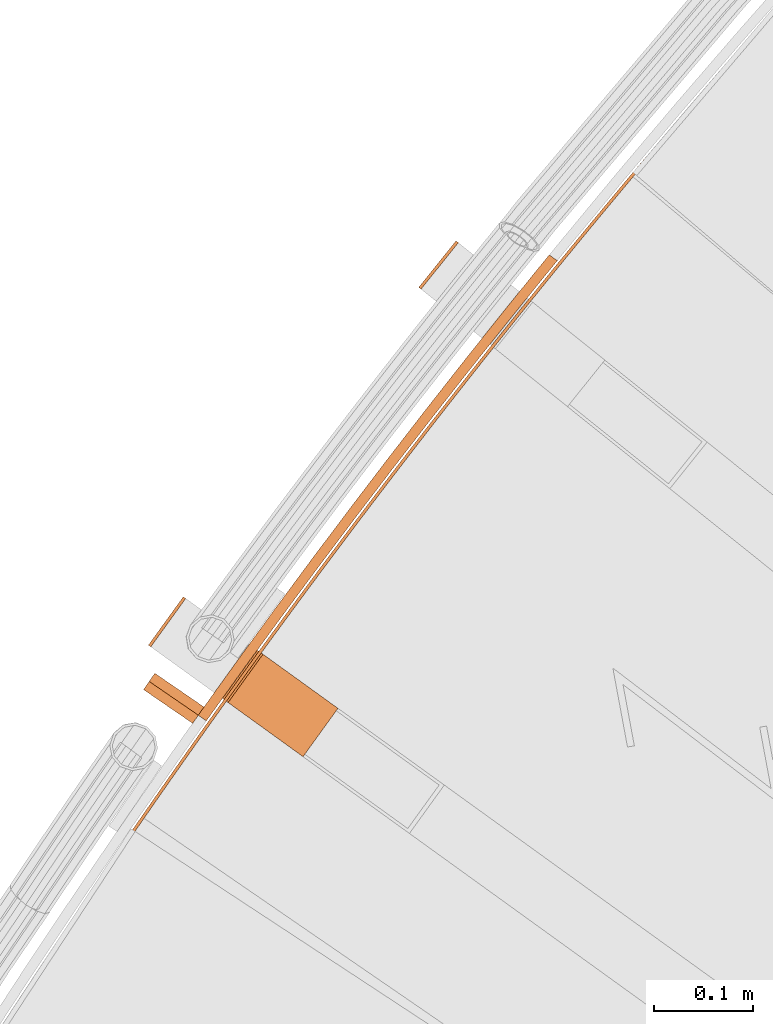
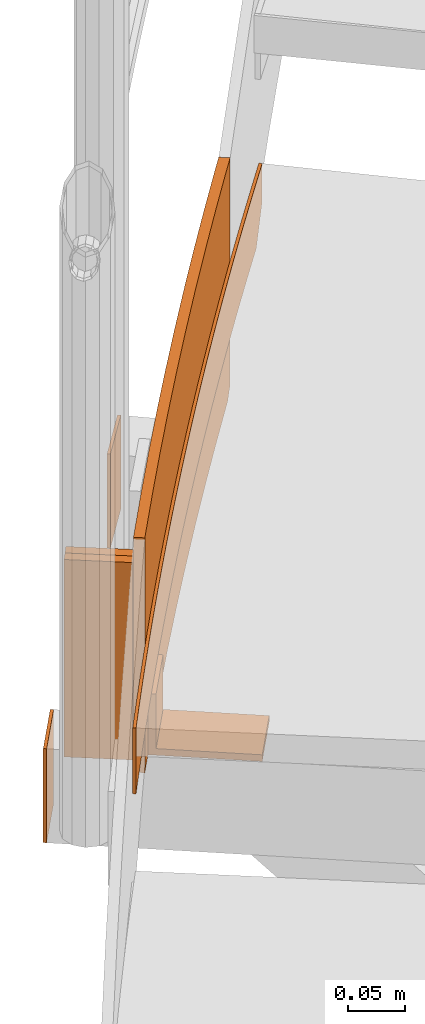
# One storey, part 64 of 126: 7 proxies.
"""IFC2X3 building model written with IfcOpenShell, lengths in millimetres."""

from ifc_helpers import new_model, si_unit, origin, origin_with_axes, place, context, project, spatial, faceted_brep, material, element, save


model = new_model("IFC2X3")

# Units and contexts
context_of_model_1 = context(None, 3, precision=0.1, world=origin())
context_of_model_2 = context(None, 3, precision=0.1, world=origin())
ifc_project = project(units=[si_unit("LENGTHUNIT", "METRE", prefix="MILLI"), si_unit("AREAUNIT", "SQUARE_METRE", prefix="CENTI"), si_unit("VOLUMEUNIT", "CUBIC_METRE", prefix="CENTI"), si_unit("MASSUNIT", "GRAM", prefix="KILO")], contexts=[context_of_model_1, context_of_model_2])

# Site, building, storey
site_placement = place(None, origin_with_axes())
site = spatial("IfcSite", under=ifc_project, at=site_placement, CompositionType="ELEMENT")
building_placement = place(site_placement, origin_with_axes())
building = spatial("IfcBuilding", under=site, at=building_placement, CompositionType="ELEMENT")
storey_placement = place(building_placement, origin_with_axes())
storey = spatial("IfcBuildingStorey", under=building, at=storey_placement, CompositionType="ELEMENT")

# Proxies
ifc_material = material(Name="S235JRG2")
proxy_1_placement = place(storey_placement, origin_with_axes())
element("IfcBuildingElementProxy", 1, at=proxy_1_placement, inside=storey, material=ifc_material, context=context_of_model_2, shape_type="Brep", body=[
    faceted_brep([(816.2356, 13130.803, 8163.85), (824.3778, 13124.997, 8163.85), (819.9333, 13118.718, 8163.85), (811.6902, 13124.381, 8163.85), (824.3778, 13124.997, 8413.85), (819.9333, 13118.718, 8413.85), (816.2356, 13130.803, 8413.85), (811.6902, 13124.381, 8413.85), (852.1953, 13180.865, 8163.85), (860.2968, 13175.002, 8163.85), (860.2968, 13175.002, 8413.85), (852.1953, 13180.865, 8413.85), (888.5037, 13230.674, 8163.85), (896.564, 13224.755, 8163.85), (896.564, 13224.755, 8413.85), (888.5037, 13230.674, 8413.85), (925.1589, 13280.229, 8163.85), (933.1777, 13274.254, 8163.85), (933.1777, 13274.254, 8413.85), (925.1589, 13280.229, 8413.85), (962.1592, 13329.527, 8163.85), (970.1361, 13323.496, 8163.85), (970.1361, 13323.496, 8413.85), (962.1592, 13329.527, 8413.85), (999.5027, 13378.565, 8163.85), (1007.4374, 13372.478, 8163.85), (1007.4374, 13372.478, 8413.85), (999.5027, 13378.565, 8413.85), (1037.1877, 13427.341, 8163.85), (1045.0796, 13421.2, 8163.85), (1045.0796, 13421.2, 8413.85), (1037.1877, 13427.341, 8413.85), (1075.2123, 13475.853, 8163.85), (1083.0612, 13469.657, 8163.85), (1083.0612, 13469.657, 8413.85), (1075.2123, 13475.853, 8413.85), (1113.5746, 13524.098, 8163.85), (1121.38, 13517.847, 8163.85), (1121.38, 13517.847, 8413.85), (1113.5746, 13524.098, 8413.85), (1152.2728, 13572.075, 8163.85), (1160.0344, 13565.769, 8163.85), (1160.0344, 13565.769, 8413.85), (1152.2728, 13572.075, 8413.85), (1156.1112, 13576.766, 8163.85), (1164.3824, 13571.083, 8163.85), (1173.0338, 13581.657, 8172.9603), (1173.0338, 13581.657, 8413.85), (1164.7625, 13587.34, 8413.85), (1164.7625, 13587.34, 8172.9603)], [[[0, 1, 2, 3]], [[1, 4, 5, 2]], [[4, 6, 7, 5]], [[0, 3, 7, 6]], [[0, 8, 9, 1]], [[1, 9, 10, 4]], [[4, 10, 11, 6]], [[6, 11, 8, 0]], [[8, 12, 13, 9]], [[9, 13, 14, 10]], [[10, 14, 15, 11]], [[11, 15, 12, 8]], [[12, 16, 17, 13]], [[13, 17, 18, 14]], [[14, 18, 19, 15]], [[15, 19, 16, 12]], [[16, 20, 21, 17]], [[17, 21, 22, 18]], [[18, 22, 23, 19]], [[19, 23, 20, 16]], [[20, 24, 25, 21]], [[21, 25, 26, 22]], [[22, 26, 27, 23]], [[23, 27, 24, 20]], [[24, 28, 29, 25]], [[25, 29, 30, 26]], [[26, 30, 31, 27]], [[27, 31, 28, 24]], [[28, 32, 33, 29]], [[29, 33, 34, 30]], [[30, 34, 35, 31]], [[31, 35, 32, 28]], [[32, 36, 37, 33]], [[33, 37, 38, 34]], [[34, 38, 39, 35]], [[35, 39, 36, 32]], [[36, 40, 41, 37]], [[37, 41, 42, 38]], [[38, 42, 43, 39]], [[39, 43, 40, 36]], [[40, 44, 45, 41]], [[41, 45, 46, 47, 42]], [[42, 47, 48, 43]], [[40, 43, 48, 49, 44]], [[46, 49, 48, 47]], [[44, 49, 46, 45]], [[2, 5, 7, 3]]]),
])
proxy_2_placement = place(storey_placement, origin_with_axes())
element("IfcBuildingElementProxy", 2, at=proxy_2_placement, inside=storey, material=ifc_material, context=context_of_model_2, shape_type="Brep", body=[
    faceted_brep([(796.7953, 13243.586, 8063.8501), (799.2281, 13241.83, 8063.8501), (764.1179, 13193.176, 8063.8501), (761.6852, 13194.931, 8063.8501), (796.7953, 13243.586, 8163.85), (761.6852, 13194.931, 8163.85), (764.1179, 13193.176, 8163.85), (799.2281, 13241.83, 8163.85)], [[[0, 1, 2, 3]], [[4, 5, 6, 7]], [[0, 4, 7, 1]], [[1, 7, 6, 2]], [[2, 6, 5, 3]], [[3, 5, 4, 0]]]),
])
proxy_3_placement = place(storey_placement, origin_with_axes())
element("IfcBuildingElementProxy", 3, at=proxy_3_placement, inside=storey, material=ifc_material, context=context_of_model_2, shape_type="Brep", body=[
    faceted_brep([(1071.0619, 13601.561, 8063.8501), (1073.4027, 13599.685, 8063.8501), (1035.8759, 13552.869, 8063.8501), (1033.5351, 13554.745, 8063.8501), (1071.0619, 13601.561, 8163.85), (1033.5351, 13554.745, 8163.85), (1035.8759, 13552.869, 8163.85), (1073.4027, 13599.685, 8163.85)], [[[0, 1, 2, 3]], [[4, 5, 6, 7]], [[0, 4, 7, 1]], [[1, 7, 6, 2]], [[2, 6, 5, 3]], [[3, 5, 4, 0]]]),
])
proxy_4_placement = place(storey_placement, origin_with_axes())
element("IfcBuildingElementProxy", 4, at=proxy_4_placement, inside=storey, material=ifc_material, context=context_of_model_2, shape_type="Brep", body=[
    faceted_brep([(737.806, 12997.733, 8243.85), (740.2786, 12996.034, 8243.85), (740.2786, 12996.034, 8313.85), (737.806, 12997.733, 8313.85), (742.7055, 13004.864, 8243.85), (745.1765, 13003.163, 8243.85), (745.1765, 13003.163, 8313.85), (742.7055, 13004.864, 8313.85), (752.5327, 13019.108, 8243.85), (755.0004, 13017.402, 8243.85), (755.0004, 13017.402, 8313.85), (752.5327, 13019.108, 8313.85), (762.3878, 13033.333, 8243.85), (764.8521, 13031.622, 8243.85), (764.8521, 13031.622, 8313.85), (762.3878, 13033.333, 8313.85), (772.2708, 13047.538, 8243.85), (774.7317, 13045.822, 8243.85), (774.7317, 13045.822, 8313.85), (772.2708, 13047.538, 8313.85), (782.1816, 13061.724, 8243.85), (784.6392, 13060.003, 8243.85), (784.6392, 13060.003, 8313.85), (782.1816, 13061.724, 8313.85), (792.1203, 13075.89, 8243.85), (794.5745, 13074.165, 8243.85), (794.5745, 13074.165, 8313.85), (792.1203, 13075.89, 8313.85), (802.0867, 13090.037, 8243.85), (804.5375, 13088.307, 8243.85), (804.5375, 13088.307, 8313.85), (802.0867, 13090.037, 8313.85), (812.0809, 13104.164, 8243.85), (814.5284, 13102.429, 8243.85), (814.5284, 13102.429, 8313.85), (812.0809, 13104.164, 8313.85), (822.1029, 13118.272, 8243.85), (824.5469, 13116.532, 8243.85), (824.5469, 13116.532, 8313.85), (822.1029, 13118.272, 8313.85), (832.1524, 13132.36, 8243.85), (834.593, 13130.615, 8243.85), (834.593, 13130.615, 8313.85), (832.1524, 13132.36, 8313.85), (842.2297, 13146.428, 8243.85), (844.6668, 13144.679, 8243.85), (844.6668, 13144.679, 8313.85), (842.2297, 13146.428, 8313.85), (852.3345, 13160.476, 8243.85), (854.7682, 13158.722, 8243.85), (854.7682, 13158.722, 8313.85), (852.3345, 13160.476, 8313.85), (862.4668, 13174.505, 8243.85), (864.8971, 13172.746, 8243.85), (864.8971, 13172.746, 8313.85), (862.4668, 13174.505, 8313.85), (872.6267, 13188.513, 8243.85), (875.0535, 13186.75, 8243.85), (875.0535, 13186.75, 8313.85), (872.6267, 13188.513, 8313.85), (882.814, 13202.502, 8243.85), (885.2374, 13200.733, 8243.85), (885.2374, 13200.733, 8313.85), (882.814, 13202.502, 8313.85), (893.0288, 13216.47, 8243.85), (895.4487, 13214.697, 8243.85), (895.4487, 13214.697, 8313.85), (893.0288, 13216.47, 8313.85), (903.271, 13230.419, 8243.85), (905.6874, 13228.641, 8243.85), (905.6874, 13228.641, 8313.85), (903.271, 13230.419, 8313.85), (913.5405, 13244.347, 8243.85), (915.9534, 13242.565, 8243.85), (915.9534, 13242.565, 8313.85), (913.5405, 13244.347, 8313.85), (923.8374, 13258.255, 8243.85), (926.2467, 13256.468, 8243.85), (926.2467, 13256.468, 8313.85), (923.8374, 13258.255, 8313.85), (934.1615, 13272.143, 8243.85), (936.5674, 13270.351, 8243.85), (936.5674, 13270.351, 8313.85), (934.1615, 13272.143, 8313.85), (944.5129, 13286.011, 8243.85), (946.9152, 13284.214, 8243.85), (946.9152, 13284.214, 8313.85), (944.5129, 13286.011, 8313.85), (954.8914, 13299.858, 8243.85), (957.2902, 13298.057, 8243.85), (957.2902, 13298.057, 8313.85), (954.8914, 13299.858, 8313.85), (965.2972, 13313.685, 8243.85), (967.6924, 13311.879, 8243.85), (967.6924, 13311.879, 8313.85), (965.2972, 13313.685, 8313.85), (975.73, 13327.492, 8243.85), (978.1217, 13325.681, 8243.85), (978.1217, 13325.681, 8313.85), (975.73, 13327.492, 8313.85), (986.1899, 13341.278, 8243.85), (988.5781, 13339.462, 8243.85), (988.5781, 13339.462, 8313.85), (986.1899, 13341.278, 8313.85), (996.6769, 13355.043, 8243.85), (999.0615, 13353.223, 8243.85), (999.0615, 13353.223, 8313.85), (996.6769, 13355.043, 8313.85), (1007.1908, 13368.788, 8243.85), (1009.5718, 13366.963, 8243.85), (1009.5718, 13366.963, 8313.85), (1007.1908, 13368.788, 8313.85), (1017.7317, 13382.512, 8243.85), (1020.1092, 13380.682, 8243.85), (1020.1092, 13380.682, 8313.85), (1017.7317, 13382.512, 8313.85), (1028.2995, 13396.216, 8243.85), (1030.6734, 13394.381, 8243.85), (1030.6734, 13394.381, 8313.85), (1028.2995, 13396.216, 8313.85), (1038.8942, 13409.898, 8243.85), (1041.2645, 13408.059, 8243.85), (1041.2645, 13408.059, 8313.85), (1038.8942, 13409.898, 8313.85), (1049.5158, 13423.56, 8243.85), (1051.8824, 13421.716, 8243.85), (1051.8824, 13421.716, 8313.85), (1049.5158, 13423.56, 8313.85), (1060.1641, 13437.201, 8243.85), (1062.5271, 13435.353, 8243.85), (1062.5271, 13435.353, 8313.85), (1060.1641, 13437.201, 8313.85), (1070.8392, 13450.821, 8243.85), (1073.1985, 13448.968, 8243.85), (1073.1985, 13448.968, 8313.85), (1070.8392, 13450.821, 8313.85), (1081.541, 13464.42, 8243.85), (1083.8967, 13462.562, 8243.85), (1083.8967, 13462.562, 8313.85), (1081.541, 13464.42, 8313.85), (1092.2694, 13477.998, 8243.85), (1094.6215, 13476.136, 8243.85), (1094.6215, 13476.136, 8313.85), (1092.2694, 13477.998, 8313.85), (1103.0245, 13491.555, 8243.85), (1105.3729, 13489.688, 8243.85), (1105.3729, 13489.688, 8313.85), (1103.0245, 13491.555, 8313.85), (1113.8062, 13505.091, 8243.85), (1116.1509, 13503.219, 8243.85), (1116.1509, 13503.219, 8313.85), (1113.8062, 13505.091, 8313.85), (1124.6144, 13518.605, 8243.85), (1126.9555, 13516.729, 8243.85), (1126.9555, 13516.729, 8313.85), (1124.6144, 13518.605, 8313.85), (1135.4492, 13532.099, 8243.85), (1137.7865, 13530.218, 8243.85), (1137.7865, 13530.218, 8313.85), (1135.4492, 13532.099, 8313.85), (1146.3103, 13545.571, 8243.85), (1148.644, 13543.686, 8243.85), (1148.644, 13543.686, 8313.85), (1146.3103, 13545.571, 8313.85), (1157.1979, 13559.022, 8243.85), (1159.5279, 13557.132, 8243.85), (1159.5279, 13557.132, 8313.85), (1157.1979, 13559.022, 8313.85), (1168.1119, 13572.451, 8243.85), (1170.4382, 13570.557, 8243.85), (1170.4382, 13570.557, 8313.85), (1168.1119, 13572.451, 8313.85), (1179.0523, 13585.859, 8243.85), (1181.3748, 13583.96, 8243.85), (1181.3748, 13583.96, 8313.85), (1179.0523, 13585.859, 8313.85), (1190.0189, 13599.245, 8243.85), (1192.3377, 13597.342, 8243.85), (1192.3377, 13597.342, 8313.85), (1190.0189, 13599.245, 8313.85), (1201.0117, 13612.61, 8243.85), (1203.3268, 13610.702, 8243.85), (1203.3268, 13610.702, 8313.85), (1201.0117, 13612.61, 8313.85), (1212.0308, 13625.953, 8243.85), (1214.3421, 13624.041, 8243.85), (1214.3421, 13624.041, 8313.85), (1212.0308, 13625.953, 8313.85), (1223.0761, 13639.275, 8243.85), (1225.3836, 13637.358, 8243.85), (1225.3836, 13637.358, 8313.85), (1223.0761, 13639.275, 8313.85), (1234.1474, 13652.575, 8243.85), (1236.4512, 13650.653, 8243.85), (1236.4512, 13650.653, 8313.85), (1234.1474, 13652.575, 8313.85), (1242.5626, 13662.644, 8243.85), (1245.0463, 13660.937, 8243.85), (1247.5449, 13663.927, 8247.7289), (1247.5449, 13663.927, 8313.85), (1245.2449, 13665.853, 8313.85), (1245.2449, 13665.853, 8248.0141), (1258.6646, 13677.179, 8264.9481), (1258.6646, 13677.179, 8313.85), (1256.3684, 13679.109, 8313.85), (1256.3684, 13679.109, 8265.2391), (1264.2375, 13683.794, 8273.556), (1264.2375, 13683.794, 8313.85), (1261.9431, 13685.727, 8313.85), (1261.9431, 13685.727, 8273.85)], [[[0, 1, 2, 3]], [[0, 4, 5, 1]], [[1, 5, 6, 2]], [[2, 6, 7, 3]], [[3, 7, 4, 0]], [[4, 8, 9, 5]], [[5, 9, 10, 6]], [[6, 10, 11, 7]], [[7, 11, 8, 4]], [[8, 12, 13, 9]], [[9, 13, 14, 10]], [[10, 14, 15, 11]], [[11, 15, 12, 8]], [[12, 16, 17, 13]], [[13, 17, 18, 14]], [[14, 18, 19, 15]], [[15, 19, 16, 12]], [[16, 20, 21, 17]], [[17, 21, 22, 18]], [[18, 22, 23, 19]], [[19, 23, 20, 16]], [[20, 24, 25, 21]], [[21, 25, 26, 22]], [[22, 26, 27, 23]], [[23, 27, 24, 20]], [[24, 28, 29, 25]], [[25, 29, 30, 26]], [[26, 30, 31, 27]], [[27, 31, 28, 24]], [[28, 32, 33, 29]], [[29, 33, 34, 30]], [[30, 34, 35, 31]], [[31, 35, 32, 28]], [[32, 36, 37, 33]], [[33, 37, 38, 34]], [[34, 38, 39, 35]], [[35, 39, 36, 32]], [[36, 40, 41, 37]], [[37, 41, 42, 38]], [[38, 42, 43, 39]], [[39, 43, 40, 36]], [[40, 44, 45, 41]], [[41, 45, 46, 42]], [[42, 46, 47, 43]], [[43, 47, 44, 40]], [[44, 48, 49, 45]], [[45, 49, 50, 46]], [[46, 50, 51, 47]], [[47, 51, 48, 44]], [[48, 52, 53, 49]], [[49, 53, 54, 50]], [[50, 54, 55, 51]], [[51, 55, 52, 48]], [[52, 56, 57, 53]], [[53, 57, 58, 54]], [[54, 58, 59, 55]], [[55, 59, 56, 52]], [[56, 60, 61, 57]], [[57, 61, 62, 58]], [[58, 62, 63, 59]], [[59, 63, 60, 56]], [[60, 64, 65, 61]], [[61, 65, 66, 62]], [[62, 66, 67, 63]], [[63, 67, 64, 60]], [[64, 68, 69, 65]], [[65, 69, 70, 66]], [[66, 70, 71, 67]], [[67, 71, 68, 64]], [[68, 72, 73, 69]], [[69, 73, 74, 70]], [[70, 74, 75, 71]], [[71, 75, 72, 68]], [[72, 76, 77, 73]], [[73, 77, 78, 74]], [[74, 78, 79, 75]], [[75, 79, 76, 72]], [[76, 80, 81, 77]], [[77, 81, 82, 78]], [[78, 82, 83, 79]], [[79, 83, 80, 76]], [[80, 84, 85, 81]], [[81, 85, 86, 82]], [[82, 86, 87, 83]], [[83, 87, 84, 80]], [[84, 88, 89, 85]], [[85, 89, 90, 86]], [[86, 90, 91, 87]], [[87, 91, 88, 84]], [[88, 92, 93, 89]], [[89, 93, 94, 90]], [[90, 94, 95, 91]], [[91, 95, 92, 88]], [[92, 96, 97, 93]], [[93, 97, 98, 94]], [[94, 98, 99, 95]], [[95, 99, 96, 92]], [[96, 100, 101, 97]], [[97, 101, 102, 98]], [[98, 102, 103, 99]], [[99, 103, 100, 96]], [[100, 104, 105, 101]], [[101, 105, 106, 102]], [[102, 106, 107, 103]], [[103, 107, 104, 100]], [[104, 108, 109, 105]], [[105, 109, 110, 106]], [[106, 110, 111, 107]], [[107, 111, 108, 104]], [[108, 112, 113, 109]], [[109, 113, 114, 110]], [[110, 114, 115, 111]], [[111, 115, 112, 108]], [[112, 116, 117, 113]], [[113, 117, 118, 114]], [[114, 118, 119, 115]], [[115, 119, 116, 112]], [[116, 120, 121, 117]], [[117, 121, 122, 118]], [[118, 122, 123, 119]], [[119, 123, 120, 116]], [[120, 124, 125, 121]], [[121, 125, 126, 122]], [[122, 126, 127, 123]], [[123, 127, 124, 120]], [[124, 128, 129, 125]], [[125, 129, 130, 126]], [[126, 130, 131, 127]], [[127, 131, 128, 124]], [[128, 132, 133, 129]], [[129, 133, 134, 130]], [[130, 134, 135, 131]], [[131, 135, 132, 128]], [[132, 136, 137, 133]], [[133, 137, 138, 134]], [[134, 138, 139, 135]], [[135, 139, 136, 132]], [[136, 140, 141, 137]], [[137, 141, 142, 138]], [[138, 142, 143, 139]], [[139, 143, 140, 136]], [[140, 144, 145, 141]], [[141, 145, 146, 142]], [[142, 146, 147, 143]], [[143, 147, 144, 140]], [[144, 148, 149, 145]], [[145, 149, 150, 146]], [[146, 150, 151, 147]], [[147, 151, 148, 144]], [[148, 152, 153, 149]], [[149, 153, 154, 150]], [[150, 154, 155, 151]], [[151, 155, 152, 148]], [[152, 156, 157, 153]], [[153, 157, 158, 154]], [[154, 158, 159, 155]], [[155, 159, 156, 152]], [[156, 160, 161, 157]], [[157, 161, 162, 158]], [[158, 162, 163, 159]], [[159, 163, 160, 156]], [[160, 164, 165, 161]], [[161, 165, 166, 162]], [[162, 166, 167, 163]], [[163, 167, 164, 160]], [[164, 168, 169, 165]], [[165, 169, 170, 166]], [[166, 170, 171, 167]], [[167, 171, 168, 164]], [[168, 172, 173, 169]], [[169, 173, 174, 170]], [[170, 174, 175, 171]], [[171, 175, 172, 168]], [[172, 176, 177, 173]], [[173, 177, 178, 174]], [[174, 178, 179, 175]], [[175, 179, 176, 172]], [[176, 180, 181, 177]], [[177, 181, 182, 178]], [[178, 182, 183, 179]], [[179, 183, 180, 176]], [[180, 184, 185, 181]], [[181, 185, 186, 182]], [[182, 186, 187, 183]], [[183, 187, 184, 180]], [[184, 188, 189, 185]], [[185, 189, 190, 186]], [[186, 190, 191, 187]], [[187, 191, 188, 184]], [[188, 192, 193, 189]], [[189, 193, 194, 190]], [[190, 194, 195, 191]], [[191, 195, 192, 188]], [[192, 196, 197, 193]], [[193, 197, 198, 199, 194]], [[194, 199, 200, 195]], [[192, 195, 200, 201, 196]], [[198, 202, 203, 199]], [[199, 203, 204, 200]], [[200, 204, 205, 201]], [[203, 202, 206, 207]], [[203, 207, 208, 204]], [[204, 208, 209, 205]], [[207, 206, 209, 208]], [[196, 201, 205, 209, 206, 202, 198, 197]]]),
])
proxy_5_placement = place(storey_placement, origin_with_axes())
element("IfcBuildingElementProxy", 5, at=proxy_5_placement, inside=storey, material=ifc_material, context=context_of_model_2, shape_type="Brep", body=[
    faceted_brep([(836.1363, 13141.206, 8228.85), (871.2465, 13189.86, 8228.85), (871.2465, 13189.86, 8163.85), (836.1363, 13141.206, 8163.85), (841.8127, 13137.11, 8228.85), (876.9229, 13185.764, 8228.85), (841.8127, 13137.11, 8170.85), (876.9229, 13185.764, 8170.85), (917.2274, 13082.689, 8170.85), (952.3376, 13131.343, 8170.85), (917.2274, 13082.689, 8163.85), (952.3376, 13131.343, 8163.85)], [[[0, 1, 2, 3]], [[0, 4, 5, 1]], [[4, 6, 7, 5]], [[6, 8, 9, 7]], [[8, 10, 11, 9]], [[3, 2, 11, 10]], [[3, 10, 8, 6, 4, 0]], [[1, 5, 7, 9, 11, 2]]]),
])
proxy_6_placement = place(storey_placement, origin_with_axes())
element("IfcBuildingElementProxy", 6, at=proxy_6_placement, inside=storey, material=ifc_material, context=context_of_model_2, shape_type="Brep", body=[
    faceted_brep([(768.1053, 13166.64, 8183.85), (762.4427, 13158.397, 8183.85), (762.4427, 13158.397, 8393.85), (768.1053, 13166.64, 8393.85), (811.8962, 13124.422, 8183.85), (817.5588, 13132.664, 8183.85), (817.5588, 13132.664, 8393.85), (811.8962, 13124.422, 8393.85)], [[[0, 1, 2, 3]], [[4, 5, 6, 7]], [[1, 4, 7, 2]], [[0, 3, 6, 5]], [[0, 5, 4, 1]], [[2, 7, 6, 3]]]),
])
proxy_7_placement = place(storey_placement, origin_with_axes())
element("IfcBuildingElementProxy", 7, at=proxy_7_placement, inside=storey, material=ifc_material, context=context_of_model_2, shape_type="Brep", body=[
    faceted_brep([(762.4427, 13158.397, 8183.85), (756.7801, 13150.155, 8183.85), (756.7801, 13150.155, 8393.85), (762.4427, 13158.397, 8393.85), (806.2336, 13116.179, 8183.85), (811.8962, 13124.422, 8183.85), (811.8962, 13124.422, 8393.85), (806.2336, 13116.179, 8393.85)], [[[0, 1, 2, 3]], [[4, 5, 6, 7]], [[1, 4, 7, 2]], [[0, 3, 6, 5]], [[0, 5, 4, 1]], [[2, 7, 6, 3]]]),
])

save(model, "model.ifc")
